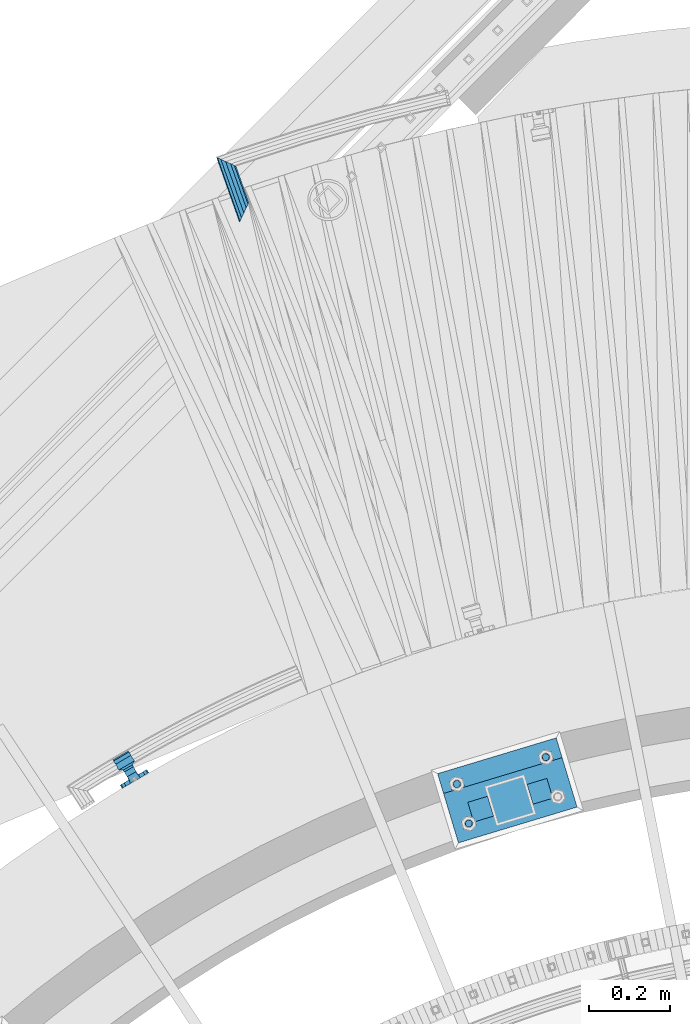
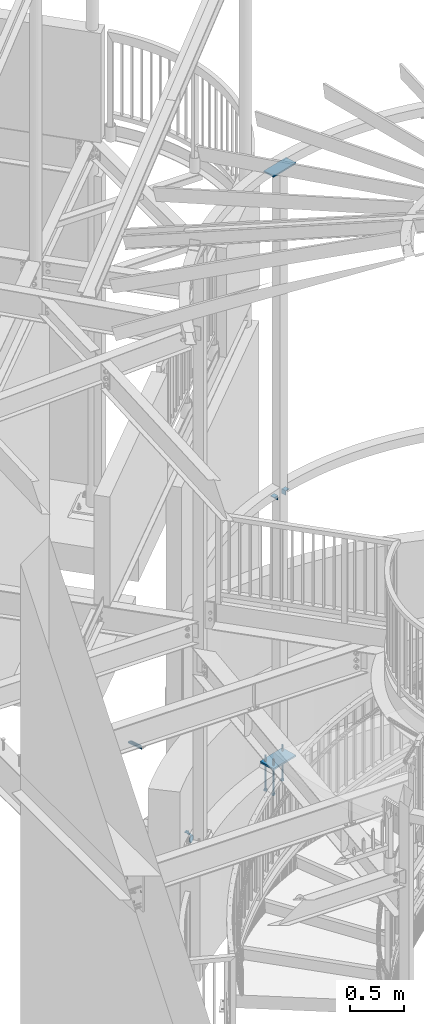
# One storey, part 515 of 975: 9 beams.
"""IFC2X3 building model written with IfcOpenShell, lengths in millimetres."""

from ifc_helpers import new_model, si_unit, frame, origin_with_axes, place, context, subcontext, project, spatial, faceted_brep, material, type_object, element, save


model = new_model("IFC2X3")

# Units and contexts
model_context = context("Model", 3, precision=1e-05, world=origin_with_axes())
body_context = subcontext(model_context, "Body", "Model", "MODEL_VIEW")
ifc_project = project(units=[si_unit("LENGTHUNIT", "METRE", prefix="MILLI"), si_unit("AREAUNIT", "SQUARE_METRE"), si_unit("VOLUMEUNIT", "CUBIC_METRE"), si_unit("MASSUNIT", "GRAM", prefix="KILO"), si_unit("TIMEUNIT", "SECOND"), si_unit("PLANEANGLEUNIT", "RADIAN"), si_unit("SOLIDANGLEUNIT", "STERADIAN"), si_unit("THERMODYNAMICTEMPERATUREUNIT", "DEGREE_CELSIUS"), si_unit("LUMINOUSINTENSITYUNIT", "LUMEN")], contexts=[model_context])

# Site, building, storey
site_placement = place(None, origin_with_axes())
site = spatial("IfcSite", under=ifc_project, at=site_placement, CompositionType="ELEMENT")
building_placement = place(site_placement, origin_with_axes())
building = spatial("IfcBuilding", under=site, at=building_placement, Name="Undefined", CompositionType="ELEMENT")
storey_placement = place(building_placement, origin_with_axes())
storey = spatial("IfcBuildingStorey", under=building, at=storey_placement, Name="Undefined", CompositionType="ELEMENT", Elevation=0.0)

# Beams
ifc_material_1 = material()
beam_type_1 = type_object("IfcBeamType", PredefinedType="NOTDEFINED")
beam_1_placement = place(storey_placement, frame((33075.7481379149, 8151.42269169121, 913.861785244744), z_axis=(-0.0568430869361109, -0.0202261951466153, 0.998178222812672), x_axis=(0.333603898901736, -0.942713332722321, -0.000104618999969072)))
element("IfcBeam", 1, at=beam_1_placement, inside=storey, type_object=beam_type_1, material=ifc_material_1, Name="HANDRAIL", context=body_context, shape_type="Brep", body=[
    faceted_brep([(36.2749286255967, 9.52499999995052, -16.4977839420928), (42.6334301021557, 16.497783941988, -9.52499999999623), (141.473891942826, 16.4977839418207, -9.52499999999054), (148.083092158022, 9.52499999975407, -16.497783942086), (27.1792150478805, 0.0, -19.050000000002), (157.535839107395, -2.18278728425503e-10, -19.0499999999945), (17.7834784767383, -9.5249999999578, -16.4977839420974), (167.299276879601, -9.52500000020518, -16.4977839420885), (10.6052989387044, -16.4977839420317, -9.52500000000373), (174.757300208224, -16.4977839423154, -9.52499999999395), (7.56806384412221, -19.049999999952, -2.27373675443232e-12), (177.911537765233, -19.0500000002357, 7.27595761418343e-12), (9.48559788380817, -16.4977839420753, 9.52499999999986), (175.916814144486, -16.4977839423664, 9.5250000000101), (15.8440993603676, -9.52500000003783, 16.4977839420962), (169.307613929289, -9.52500000029249, 16.4977839421053), (24.939812938087, -9.45874489843845e-11, 19.0500000000056), (159.854866979916, -3.20142135024071e-10, 19.0500000000138), (34.3355495092278, 9.52499999986321, 16.497783942101), (150.091429207714, 9.52499999966676, 16.4977839421076), (41.5137290472626, 16.4977839419444, 9.52500000000737), (142.633405879086, 16.497783941777, 9.52500000001328), (44.5509641418444, 19.0499999998647, 5.91171556152403e-12), (139.479168322079, 19.0499999996973, 1.22781784739345e-11), (32.7355159760868, 7.68349999988277, 13.3082123799622), (25.1562884753671, -8.00355337560177e-11, 15.3670000000047), (17.8190795226737, -7.68350000004284, 13.3082123799581), (12.6898883315812, -13.3082123799541, 7.68350000000032), (11.1430775395675, -15.3669999999693, -1.36424205265939e-12), (13.5931138491992, -13.3082123799104, -7.68350000000305), (19.3835120098793, -7.68349999997008, -13.3082123799584), (26.9627395105986, -7.27595761418343e-12, -15.3670000000011), (34.2999484632924, 7.68349999994825, -13.3082123799545), (39.4291396543854, 13.3082123798595, -7.68349999999668), (40.9759504463982, 15.366999999882, 5.45696821063757e-12), (38.5259141367669, 13.3082123798231, 7.68350000000669), (174.19640871906, -15.3670000002458, 8.18545231595635e-12), (171.651990423074, -13.3082123801869, -7.68349999999327), (165.63585160465, -7.68350000022474, -13.3082123799495), (157.760011801737, -2.3283064365387e-10, -15.3669999999934), (150.134795929244, 7.68349999974453, -13.3082123799472), (144.803374422318, 13.3082123796848, -7.68349999999009), (143.19429736825, 15.3669999997073, 1.13686837721616e-11), (145.738715664237, 13.3082123796412, 7.68350000001283), (151.75485448266, 7.68349999967904, 13.3082123799691), (159.630694285574, -3.05590219795704e-10, 15.3670000000129), (167.255910158066, -7.68350000029022, 13.308212379967), (172.587331664992, -13.3082123802233, 7.68350000000964)], [[[0, 1, 2, 3]], [[4, 0, 3, 5]], [[6, 4, 5, 7]], [[8, 6, 7, 9]], [[10, 8, 9, 11]], [[12, 10, 11, 13]], [[14, 12, 13, 15]], [[16, 14, 15, 17]], [[18, 16, 17, 19]], [[20, 18, 19, 21]], [[22, 20, 21, 23]], [[1, 22, 23, 2]], [[0, 4, 6, 8, 10, 12, 14, 16, 18, 20, 22, 1], [24, 25, 26, 27, 28, 29, 30, 31, 32, 33, 34, 35]], [[29, 28, 36, 37]], [[30, 29, 37, 38]], [[31, 30, 38, 39]], [[32, 31, 39, 40]], [[33, 32, 40, 41]], [[34, 33, 41, 42]], [[35, 34, 42, 43]], [[24, 35, 43, 44]], [[25, 24, 44, 45]], [[26, 25, 45, 46]], [[27, 26, 46, 47]], [[28, 27, 47, 36]], [[7, 5, 3, 2, 23, 21, 19, 17, 15, 13, 11, 9], [46, 45, 44, 43, 42, 41, 40, 39, 38, 37, 36, 47]]]),
])
ifc_material_2 = material(Name="STEEL/A36")
beam_type_2 = type_object("IfcBeamType", PredefinedType="NOTDEFINED")
beam_2_placement = place(storey_placement, frame((32856.3238851668, 6612.17309210685, 812.475739928615), z_axis=(-0.862992370275511, -0.505216917161317, 0.000188308976052212), x_axis=(0.505216929992915, -0.862992382987531, 2.35380000032378e-05)))
element("IfcBeam", 2, at=beam_2_placement, inside=storey, type_object=beam_type_2, material=ifc_material_2, Name="WALL BRACKET", context=body_context, shape_type="Brep", body=[
    faceted_brep([(-1.09139364212751e-11, -35.1998101886752, 14.5802387730655), (0.0, -26.940768363208, 26.9407683632162), (1.2732925824821e-11, -14.5802387731151, 35.1998101887366), (0.0, 0.0, 38.0999984741211), (3.27418092638254e-11, 14.5802387730973, 35.1998101888166), (3.45607986673713e-11, 26.9407683631939, 26.9407683633472), (3.27418092638254e-11, 35.1998101886679, 14.5802387732328), (2.36468622460961e-11, 38.0999999999908, 8.73114913702011e-11), (1.45519152283669e-11, 35.1998101886752, -14.5802387730655), (1.81898940354586e-12, 26.9407683632071, -26.9407683632162), (-1.09139364212751e-11, 14.5802387731146, -35.1998101887511), (0.0, 0.0, -38.0999984741211), (-2.91038304567337e-11, -14.5802387730978, -35.1998101888239), (-3.27418092638254e-11, -26.9407683631948, -26.9407683633617), (-3.09228198602796e-11, -35.1998101886688, -14.5802387732401), (-2.36468622460961e-11, -38.0999999999917, -9.45874489843845e-11), (9.52499999999407, 35.4440469783465, 13.3523775149006), (9.52500000001783, 38.099999999989, 1.23691279441118e-10), (5.45819490078651, 35.1998101886775, 14.58023877304), (5.15915812204861, 35.4440469814256, 13.3523774994246), (5.15916016817869, 35.4440461871586, -13.3523814925829), (5.45819607316758, 35.1998101886757, -14.5802387731565), (9.52499999563867, 35.4440461839649, -13.352381508641), (9.52499999999338, 33.7468954266617, -16.754679378646), (9.52499999999418, 26.9407683632057, -26.9407683631944), (7.23710514487385, 33.7468954167059, -16.7546793935435), (9.52499999997963, 14.5802387731133, -35.199810188722), (9.52499999996871, 7.73070496506989e-12, -38.1000000000931), (9.52499999996326, -14.5802387730996, -35.1998101888021), (9.52499999995962, -26.9407683631966, -26.9407683633399), (9.5249999999578, -35.1998101886768, -14.5802387731064), (9.52499999997235, -38.0999999999935, -7.27595761418343e-11), (9.52499999988504, -35.1998101886779, 14.5802387731401), (9.52499999999418, -26.9407683632098, 26.940768363238), (9.52500000000691, -14.5802387731169, 35.1998101887584), (9.52500000001783, -1.13686837721616e-11, 38.1000000001295), (9.5250000000251, 14.580238773096, 35.1998101888312), (9.52500000002692, 26.9407683631925, 26.9407683633617), (7.23710629084189, 33.7468933804012, 16.7546824409801), (9.52500001802099, 33.74689339, 16.7546824266137), (4.12737783423069, 36.2867482851609, 11.6630037101459), (9.52500001480979, 36.2867482910076, 11.6630037099276), (1.9072828969438, 38.0999998001848, -4.3824766180478e-06), (9.43529109937867, 38.0999998083389, -4.38277129433118e-06), (4.12738199474541, 36.2867456530334, -11.6630120660157), (9.52499999713365, 36.2867456588801, -11.6630120662267), (9.52499998931302, 31.8782691818908, -20.5007361535354), (1.90728516843444, 38.0999984362613, -14.9620414784949), (9.43529504267332, 38.0999984471014, -14.9620414798228), (9.52499998867484, 31.8782692100656, -21.3428983101403), (-0.974480980704527, 40.4536660864392, -13.6176374922397), (6.55352889353486, 40.4536660972792, -13.617637493564), (-3.23293929398841, 48.4467136552532, -12.2071016444133), (-3.86099316375032, 48.9596734302611, -12.3332393299024), (-3.86099415506237, 48.9596734359397, 12.1506042690053), (-3.23294234398753, 48.4467162038179, 12.0244673261113), (6.55352388489973, 40.4536689343606, 13.4350048968336), (9.4352891744017, 38.1000015670843, 14.7794093900302), (-8.88876894391092, 51.462646060533, -12.9487245784876), (-14.5044020842531, 51.5524567377918, -12.9708091785214), (-14.5044031272276, 51.5524567437842, 12.788173508583), (-8.88876998507754, 51.4626460665079, 12.7660889411018), (-16.4483770195459, 51.1442726592504, -12.8704360163174), (-16.4483780543928, 51.1442726651987, 12.6878004343525), (-22.5793182144077, 51.3711360271759, -12.9262221073186), (-22.5793192537777, 51.3711360331463, 12.7435864607032), (-27.8885284154861, 54.4455780358899, -13.6822326528272), (-27.8885295160832, 54.4455780422152, 13.4995963000001), (-28.6196515649072, 55.6169452716154, -13.9702738582564), (-31.1370083013608, 59.6501226213948, -17.5950925222933), (-31.1370097188383, 59.6501226295447, 17.4124524185645), (-28.6196545294583, 55.616948227025, 13.7876379643458), (-33.6296792490059, 67.324805151891, -22.2250062266612), (-32.8101722890036, 64.8016260361878, -22.2250061928717), (-39.3161821982224, 64.9509398614337, -22.2250064563596), (-33.6296810489844, 67.3248051619378, 22.2249937734341), (-39.3127719838823, 64.95236112884, 22.2249935438595), (-32.8101756191698, 64.8016307577993, 22.2249938072164), (-49.8281982508399, 63.7590297560901, -21.2879733583577), (-49.8281999673757, 63.7590297658239, 21.1053316176076), (-62.537662592724, 64.8016282183019, -22.2250073966388), (-62.5376643923654, 64.8016282284259, 22.2249926034456), (-59.3629825026719, 68.3509998487543, 22.2249927311568), (-59.3629807030303, 68.3509998386305, -22.2250072689349), (-56.0005505059879, 61.6533412669896, 22.2249928688907), (-56.0009816237271, 61.6535489521873, 19.2130312653135), (-56.0009816302269, 64.8016307505561, 22.0423689734525), (-51.9930603186979, 64.8016307660225, 22.2249930304133), (-51.9930486616773, 64.8016260085653, -22.2250069696784), (-56.000981616694, 61.6535497473442, -22.2250071312228), (-56.0009816212363, 64.8016260027941, -22.2250068759422), (-56.0009816161877, 61.6535496925769, -19.3956728877092), (-50.6240356350016, 59.0640018412871, -17.0683164176735), (-50.6240370098228, 59.0640018490833, 16.8856764812081), (-37.4851004069614, 60.555058921409, -18.4084041452843), (-37.4851018904596, 60.555058929803, 18.2257636742615), (-36.5628425975134, 60.9400579463424, -18.7544220673662), (-36.5628441090176, 60.9400579547794, 18.5717814508498), (-35.6661101826384, 58.1791091500552, -16.2730189810172), (-35.6661114930633, 58.1791091575863, 16.0903794298065), (-34.0669073739811, 55.616948225869, 13.7876379531408), (-34.0669044052501, 55.6169452637716, -13.9702738572996), (-31.199578137138, 51.0230652214489, -12.8406309028251), (-31.1995791695818, 51.0230652273826, 12.6579953160217), (-13.5258453474495, 46.8920843628518, -12.4814476045976), (-10.0158535806146, 46.8359491542703, -12.491353805628), (-10.0158545847443, 46.8359491600327, 12.308720278641), (-13.5258463507973, 46.8920843686235, 12.298814059428), (-15.4698202757649, 46.4839002842855, -12.5534799881534), (-15.469821284944, 46.4839002900824, 12.3708465294185), (-23.8996230795056, 46.7958284847284, -12.4984339079674), (-23.8996240842331, 46.7958284904998, 12.3158003666576), (-26.7505131823156, 48.4467136213889, -12.207101640266), (-26.7505186046602, 48.4467161988273, 12.0244672777189), (-6.87329577845111, 45.2714927334573, -12.7674339683217), (-6.87329680492121, 45.2714927393397, 12.584800790275), (-0.974485553301008, 40.4536689327629, 13.4350048813394), (1.90728014135857, 38.100001565487, 14.7794093745397), (9.52500002100476, 31.8782677827221, 21.320715892205), (9.52500002038346, 31.878267810155, 20.5007393728483)], [[[0, 1, 2, 3, 4, 5, 6, 7, 8, 9, 10, 11, 12, 13, 14, 15]], [[16, 17, 7, 6, 18, 19]], [[20, 21, 8, 7, 17, 22]], [[23, 24, 9, 8, 21, 25]], [[10, 9, 24, 26]], [[11, 10, 26, 27]], [[12, 11, 27, 28]], [[13, 12, 28, 29]], [[14, 13, 29, 30]], [[15, 14, 30, 31]], [[0, 15, 31, 32]], [[1, 0, 32, 33]], [[2, 1, 33, 34]], [[3, 2, 34, 35]], [[4, 3, 35, 36]], [[5, 4, 36, 37]], [[38, 18, 6, 5, 37, 39]], [[39, 37, 36, 35, 34, 33, 32, 31, 30, 29, 28, 27, 26, 24, 23, 22, 17, 16]], [[40, 41, 16, 19]], [[40, 42, 43, 41]], [[42, 44, 45, 43]], [[46, 23, 25]], [[47, 48, 49]], [[48, 47, 50, 51]], [[51, 52, 53, 54, 55, 56, 57, 48]], [[58, 59, 60, 61]], [[59, 62, 63, 60]], [[62, 64, 65, 63]], [[64, 66, 67, 65]], [[66, 68, 69, 70, 71, 67]], [[72, 73, 74]], [[75, 76, 77]], [[74, 76, 75, 72]], [[74, 78, 79, 76]], [[80, 81, 82, 83]], [[84, 85, 86]], [[82, 81, 84, 86, 87]], [[78, 88, 83, 82, 87, 79]], [[89, 80, 83, 88, 90]], [[89, 90, 91]], [[84, 81, 80, 89, 91, 92, 93, 85]], [[92, 94, 95, 93]], [[94, 96, 97, 95]], [[96, 98, 99, 97]], [[70, 77, 76, 79, 87, 86, 85, 93, 95, 97, 99, 100, 71]], [[69, 73, 72, 75, 77, 70]], [[68, 101, 98, 96, 94, 92, 91, 90, 88, 78, 74, 73, 69]], [[99, 98, 101, 102, 103, 100]], [[104, 105, 106, 107]], [[108, 104, 107, 109]], [[110, 108, 109, 111]], [[103, 102, 112, 110, 111, 113]], [[54, 61, 60, 63, 65, 67, 71, 100, 103, 113, 55]], [[53, 58, 61, 54]], [[52, 112, 102, 101, 68, 66, 64, 62, 59, 58, 53]], [[51, 50, 114, 105, 104, 108, 110, 112, 52]], [[105, 114, 115, 106]], [[55, 113, 111, 109, 107, 106, 115, 116, 56]], [[56, 116, 117, 57]], [[117, 118, 57]], [[39, 16, 41, 43, 45, 22, 23, 46, 49, 48, 57, 118, 119]], [[119, 38, 39]], [[119, 118, 117, 116, 115, 114, 50, 47, 49, 46, 25, 21, 20, 44, 42, 40, 19, 18, 38]], [[45, 44, 20, 22]]]),
])
beam_type_3 = type_object("IfcBeamType", Name="L2X2X1/4", PredefinedType="NOTDEFINED")
for number, where, z_axis, x_axis, name in (
    (3, (33703.1314159098, 6558.02226076022, 4445.0), (-0.957369928409554, -0.288864709123642, 0.0), (0.288864709123643, -0.957369928409553, 0.0), "ANGLE"),
    (4, (33863.7089202229, 6553.41085006745, 4445.0), (0.957369928409554, 0.288864709123642, 0.0), (-0.288864709123643, 0.957369928409553, 0.0), "ANGLE"),
):
    element("IfcBeam", number, at=place(storey_placement, frame(where, z_axis=z_axis, x_axis=x_axis)), inside=storey, type_object=beam_type_3, material=ifc_material_2, Name=name, ObjectType="L2X2X1/4", context=body_context, shape_type="Brep", body=[
        faceted_brep([(0.0, 25.3999999999724, -25.4000000000342), (0.0, 25.400000000016, 25.4000000000196), (50.8000000000102, 25.3999999999996, 25.4000000000015), (50.7999999999411, 25.3999999999996, -25.4000000000487), (3.27418092638254e-11, 19.0500000000002, 25.4000000000269), (50.8000000000102, 19.0500000000002, 25.4000000000015), (-2.5465851649642e-11, 19.0500000000002, -19.0500000000211), (50.7999999999483, 19.0500000000002, -19.0500000000429), (-2.5465851649642e-11, -25.3999999999996, -19.0500000000211), (50.7999999999483, -25.3999999999996, -19.0500000000429), (0.0, -25.400000000016, -25.4000000000196), (50.7999999999411, -25.3999999999996, -25.4000000000487)], [[[0, 1, 2, 3]], [[1, 4, 5, 2]], [[4, 6, 7, 5]], [[6, 8, 9, 7]], [[8, 10, 11, 9]], [[10, 0, 3, 11]], [[5, 7, 9, 11, 3, 2]], [[10, 8, 6, 4, 1, 0]]]),
    ])
beam_type_4 = type_object("IfcBeamType", PredefinedType="NOTDEFINED")
beam_3_placement = place(storey_placement, frame((33637.5169909779, 6511.69357374351, 8170.8625), z_axis=(0.288864709123643, -0.957369928409553, 0.0), x_axis=(0.957369928409554, 0.288864709123642, 0.0)))
element("IfcBeam", 5, at=beam_3_placement, inside=storey, type_object=beam_type_4, material=ifc_material_2, Name="PLATE", context=body_context, shape_type="Brep", body=[
    faceted_brep([(0.0, 7.9375, -63.5), (0.0, 7.9375, 63.5), (304.799999999529, 7.9375, 63.5), (304.799999999529, 7.9375, -63.5), (0.0, -7.9375, 63.5), (304.799999999529, -7.9375, 63.5), (0.0, -7.9375, -63.5), (304.799999999529, -7.9375, -63.5)], [[[0, 1, 2, 3]], [[1, 4, 5, 2]], [[4, 6, 7, 5]], [[6, 0, 3, 7]], [[5, 7, 3, 2]], [[6, 4, 1, 0]]]),
])
ifc_material_3 = material(Name="STEEL/F1554-36")
beam_type_5 = type_object("IfcBeamType", PredefinedType="NOTDEFINED")
beam_4_placement = place(storey_placement, frame((33870.8360600783, 6661.6853801861, 1371.6), z_axis=(-0.957369928409554, -0.288864709123642, 0.0), x_axis=(0.0, 0.0, -1.0)))
element("IfcBeam", 6, at=beam_4_placement, inside=storey, type_object=beam_type_5, material=ifc_material_3, Name="HEADED_ANCHOR_BOLT", context=body_context, shape_type="Brep", body=[
    faceted_brep([(260.34375, -9.13000011445183, 15.8100004195221), (260.34375, -18.2600002289691, -1.45519152283669e-11), (279.393749999999, -18.2600002289691, -1.45519152283669e-11), (279.393749999999, -9.13000011445183, 15.8100004195221), (260.34375, 9.13000011451732, 15.8100004195403), (279.393749999999, 9.13000011451732, 15.8100004195403), (260.34375, 18.2600002289728, 1.81898940354586e-11), (279.393749999999, 18.2600002289728, 1.81898940354586e-11), (260.34375, 9.13000011445547, -15.8100004195221), (279.393749999999, 9.13000011445547, -15.8100004195221), (260.34375, -9.13000011451732, -15.8100004195367), (279.393749999999, -9.13000011451732, -15.8100004195367), (260.34375, -4.47768005528269, 9.29799844174704), (260.34375, -8.06850066050174, 6.43441456486471), (260.34375, -10.0612557562381, 2.29641597050068), (260.34375, -10.0612557562454, -2.29641597051523), (260.34375, -8.06850066052721, -6.43441456487926), (260.34375, -4.47768005531907, -9.29799844175068), (260.34375, -1.81898940354586e-11, -10.319999694766), (260.34375, 4.47768005528633, -9.2979984417434), (260.34375, 8.06850066050174, -6.43441456486471), (260.34375, 10.0612557562381, -2.29641597050068), (260.34375, 10.0612557562454, 2.29641597051886), (260.34375, 8.06850066052357, 6.4344145648829), (260.34375, 4.47768005532271, 9.29799844175432), (260.34375, 2.18278728425503e-11, 10.3199996947696), (279.393749999999, 2.18278728425503e-11, 10.3199996947696), (279.393749999999, -4.47768005528269, 9.29799844174704), (279.393749999999, -8.06850066050174, 6.43441456486471), (279.393749999999, -10.0612557562381, 2.29641597050068), (279.393749999999, -10.0612557562454, -2.29641597051523), (279.393749999999, -8.06850066052721, -6.43441456487926), (279.393749999999, -4.47768005531907, -9.29799844175068), (279.393749999999, -1.81898940354586e-11, -10.319999694766), (279.393749999999, 4.47768005528633, -9.2979984417434), (279.393749999999, 8.06850066050174, -6.43441456486471), (279.393749999999, 10.0612557562381, -2.29641597050068), (279.393749999999, 10.0612557562454, 2.29641597051886), (279.393749999999, 8.06850066052357, 6.4344145648829), (279.393749999999, 4.47768005532271, 9.29799844175432), (0.0, -6.73519209080223, 6.73519209080186), (0.0, -9.52499999999964, 0.0), (279.400000000001, -9.52499999999782, -3.63797880709171e-12), (279.400000000001, -6.73519209079313, 6.73519209079313), (-9.87109982941227e-13, -1.20792265079217e-13, 9.52499961853027), (279.400000000001, 1.09139364212751e-11, 9.52499999999054), (0.0, 6.73519209080223, 6.73519209080186), (279.400000000001, 6.73519209081132, 6.73519209079677), (0.0, 9.52499999999964, 0.0), (279.400000000001, 9.52500000000146, 3.63797880709171e-12), (0.0, 6.73519209080223, -6.73519209080186), (279.400000000001, 6.73519209079677, -6.73519209079313), (2.95075507493764e-12, -1.20792265079217e-13, -9.52499961853027), (279.400000000001, -1.09139364212751e-11, -9.5249999999869), (-126.99791499542, -6.36396103070001, 6.3639610306418), (-126.99791499542, 1.81898940354586e-11, 8.99999999995271), (-126.99791499542, 6.36396103072184, 6.36396103065272), (-126.99791499542, 9.00000000004366, 1.09139364212751e-11), (-126.99791499542, 6.36396103069637, -6.3639610306418), (-126.99791499542, -1.81898940354586e-11, -8.99999999995271), (-126.99791499542, -6.36396103072184, -6.36396103064908), (-126.99791499542, -9.00000000004002, -7.27595761418343e-12), (0.0149743263646087, 6.36396103067818, -6.36396103067909), (0.0149743263646087, 0.0, -9.0), (0.0149743263646087, -6.36396103067818, -6.36396103067909), (0.0149743263987148, -8.9999995411581, -1.00796984270346e-06), (0.0149743263646087, -6.36396103067818, 6.36396103067909), (0.0149743263646087, 0.0, 9.0), (0.0149743263646087, 6.36396103067818, 6.36396103067909), (0.0149743263987148, 9.0000004588419, -1.00796984270346e-06), (0.0, -6.73519209080223, -6.73519209080186), (279.400000000001, -6.73519209080769, -6.73519209079677)], [[[0, 1, 2, 3]], [[4, 0, 3, 5]], [[6, 4, 5, 7]], [[8, 6, 7, 9]], [[10, 8, 9, 11]], [[0, 4, 6, 8, 10, 1], [12, 13, 14, 15, 16, 17, 18, 19, 20, 21, 22, 23, 24, 25]], [[12, 25, 26, 27]], [[13, 12, 27, 28]], [[14, 13, 28, 29]], [[15, 14, 29, 30]], [[16, 15, 30, 31]], [[17, 16, 31, 32]], [[18, 17, 32, 33]], [[19, 18, 33, 34]], [[20, 19, 34, 35]], [[21, 20, 35, 36]], [[22, 21, 36, 37]], [[23, 22, 37, 38]], [[24, 23, 38, 39]], [[25, 24, 39, 26]], [[9, 7, 5, 3, 2, 11], [38, 37, 36, 35, 34, 33, 32, 31, 30, 29, 28, 27, 26, 39]], [[1, 10, 11, 2]], [[40, 41, 42, 43]], [[44, 40, 43, 45]], [[46, 44, 45, 47]], [[48, 46, 47, 49]], [[50, 48, 49, 51]], [[52, 50, 51, 53]], [[54, 55, 56, 57, 58, 59, 60, 61]], [[59, 58, 62, 63]], [[60, 59, 63, 64]], [[61, 60, 64, 65]], [[54, 61, 65, 66]], [[55, 54, 66, 67]], [[56, 55, 67, 68]], [[57, 56, 68, 69]], [[58, 57, 69, 62]], [[40, 44, 46, 48, 50, 52, 70, 41], [68, 67, 66, 65, 64, 63, 62, 69]], [[41, 70, 71, 42]], [[53, 51, 49, 47, 45, 43, 42, 71]], [[70, 52, 53, 71]]]),
])
beam_5_placement = place(storey_placement, frame((33681.3299546868, 6498.38212477162, 1371.6), z_axis=(0.957369928409554, 0.288864709123642, 0.0), x_axis=(0.0, 0.0, -1.0)))
element("IfcBeam", 7, at=beam_5_placement, inside=storey, type_object=beam_type_5, material=ifc_material_3, Name="HEADED_ANCHOR_BOLT", context=body_context, shape_type="Brep", body=[
    faceted_brep([(260.34375, -9.13000011445183, 15.8100004195221), (260.34375, -18.2600002289691, -1.45519152283669e-11), (279.393749999999, -18.2600002289691, -1.45519152283669e-11), (279.393749999999, -9.13000011445183, 15.8100004195221), (260.34375, 9.13000011451732, 15.8100004195403), (279.393749999999, 9.13000011451732, 15.8100004195403), (260.34375, 18.2600002289728, 1.81898940354586e-11), (279.393749999999, 18.2600002289728, 1.81898940354586e-11), (260.34375, 9.13000011445547, -15.8100004195221), (279.393749999999, 9.13000011445547, -15.8100004195221), (260.34375, -9.13000011451732, -15.8100004195367), (279.393749999999, -9.13000011451732, -15.8100004195367), (260.34375, -4.47768005528269, 9.29799844174704), (260.34375, -8.06850066050174, 6.43441456486471), (260.34375, -10.0612557562381, 2.29641597050068), (260.34375, -10.0612557562454, -2.29641597051523), (260.34375, -8.06850066052721, -6.43441456487926), (260.34375, -4.47768005531907, -9.29799844175068), (260.34375, -1.81898940354586e-11, -10.319999694766), (260.34375, 4.47768005528633, -9.2979984417434), (260.34375, 8.06850066050174, -6.43441456486471), (260.34375, 10.0612557562381, -2.29641597050068), (260.34375, 10.0612557562454, 2.29641597051886), (260.34375, 8.06850066052357, 6.4344145648829), (260.34375, 4.47768005532271, 9.29799844175432), (260.34375, 2.18278728425503e-11, 10.3199996947696), (279.393749999999, 2.18278728425503e-11, 10.3199996947696), (279.393749999999, -4.47768005528269, 9.29799844174704), (279.393749999999, -8.06850066050174, 6.43441456486471), (279.393749999999, -10.0612557562381, 2.29641597050068), (279.393749999999, -10.0612557562454, -2.29641597051523), (279.393749999999, -8.06850066052721, -6.43441456487926), (279.393749999999, -4.47768005531907, -9.29799844175068), (279.393749999999, -1.81898940354586e-11, -10.319999694766), (279.393749999999, 4.47768005528633, -9.2979984417434), (279.393749999999, 8.06850066050174, -6.43441456486471), (279.393749999999, 10.0612557562381, -2.29641597050068), (279.393749999999, 10.0612557562454, 2.29641597051886), (279.393749999999, 8.06850066052357, 6.4344145648829), (279.393749999999, 4.47768005532271, 9.29799844175432), (0.0, -6.73519209080223, 6.73519209080186), (0.0, -9.52499999999964, 0.0), (279.400000000001, -9.52499999999782, -3.63797880709171e-12), (279.400000000001, -6.73519209079313, 6.73519209079313), (-9.87109982941227e-13, -1.20792265079217e-13, 9.52499961853027), (279.400000000001, 1.09139364212751e-11, 9.52499999999054), (0.0, 6.73519209080223, 6.73519209080186), (279.400000000001, 6.73519209081132, 6.73519209079677), (0.0, 9.52499999999964, 0.0), (279.400000000001, 9.52500000000146, 3.63797880709171e-12), (0.0, 6.73519209080223, -6.73519209080186), (279.400000000001, 6.73519209079677, -6.73519209079313), (2.95075507493764e-12, -1.20792265079217e-13, -9.52499961853027), (279.400000000001, -1.09139364212751e-11, -9.5249999999869), (-126.99791499542, -6.36396103070001, 6.3639610306418), (-126.99791499542, 1.81898940354586e-11, 8.99999999995271), (-126.99791499542, 6.36396103072184, 6.36396103065272), (-126.99791499542, 9.00000000004366, 1.09139364212751e-11), (-126.99791499542, 6.36396103069637, -6.3639610306418), (-126.99791499542, -1.81898940354586e-11, -8.99999999995271), (-126.99791499542, -6.36396103072184, -6.36396103064908), (-126.99791499542, -9.00000000004002, -7.27595761418343e-12), (0.0149743263646087, 6.36396103067818, -6.36396103067909), (0.0149743263646087, 0.0, -9.0), (0.0149743263646087, -6.36396103067818, -6.36396103067909), (0.0149743263987148, -8.9999995411581, -1.00796984270346e-06), (0.0149743263646087, -6.36396103067818, 6.36396103067909), (0.0149743263646087, 0.0, 9.0), (0.0149743263646087, 6.36396103067818, 6.36396103067909), (0.0149743263987148, 9.0000004588419, -1.00796984270346e-06), (0.0, -6.73519209080223, -6.73519209080186), (279.400000000001, -6.73519209080769, -6.73519209079677)], [[[0, 1, 2, 3]], [[4, 0, 3, 5]], [[6, 4, 5, 7]], [[8, 6, 7, 9]], [[10, 8, 9, 11]], [[0, 4, 6, 8, 10, 1], [12, 13, 14, 15, 16, 17, 18, 19, 20, 21, 22, 23, 24, 25]], [[12, 25, 26, 27]], [[13, 12, 27, 28]], [[14, 13, 28, 29]], [[15, 14, 29, 30]], [[16, 15, 30, 31]], [[17, 16, 31, 32]], [[18, 17, 32, 33]], [[19, 18, 33, 34]], [[20, 19, 34, 35]], [[21, 20, 35, 36]], [[22, 21, 36, 37]], [[23, 22, 37, 38]], [[24, 23, 38, 39]], [[25, 24, 39, 26]], [[9, 7, 5, 3, 2, 11], [38, 37, 36, 35, 34, 33, 32, 31, 30, 29, 28, 27, 26, 39]], [[1, 10, 11, 2]], [[40, 41, 42, 43]], [[44, 40, 43, 45]], [[46, 44, 45, 47]], [[48, 46, 47, 49]], [[50, 48, 49, 51]], [[52, 50, 51, 53]], [[54, 55, 56, 57, 58, 59, 60, 61]], [[59, 58, 62, 63]], [[60, 59, 63, 64]], [[61, 60, 64, 65]], [[54, 61, 65, 66]], [[55, 54, 66, 67]], [[56, 55, 67, 68]], [[57, 56, 68, 69]], [[58, 57, 69, 62]], [[40, 44, 46, 48, 50, 52, 70, 41], [68, 67, 66, 65, 64, 63, 62, 69]], [[41, 70, 71, 42]], [[53, 51, 49, 47, 45, 43, 42, 71]], [[70, 52, 53, 71]]]),
])
beam_6_placement = place(storey_placement, frame((33651.9812944246, 6595.65090774363, 1371.6), z_axis=(-0.957369928409554, -0.288864709123642, 0.0), x_axis=(0.0, 0.0, -1.0)))
element("IfcBeam", 8, at=beam_6_placement, inside=storey, type_object=beam_type_5, material=ifc_material_3, Name="HEADED_ANCHOR_BOLT", context=body_context, shape_type="Brep", body=[
    faceted_brep([(260.34375, -9.13000011445183, 15.8100004195221), (260.34375, -18.2600002289691, -1.45519152283669e-11), (279.393749999999, -18.2600002289691, -1.45519152283669e-11), (279.393749999999, -9.13000011445183, 15.8100004195221), (260.34375, 9.13000011451732, 15.8100004195403), (279.393749999999, 9.13000011451732, 15.8100004195403), (260.34375, 18.2600002289728, 1.81898940354586e-11), (279.393749999999, 18.2600002289728, 1.81898940354586e-11), (260.34375, 9.13000011445547, -15.8100004195221), (279.393749999999, 9.13000011445547, -15.8100004195221), (260.34375, -9.13000011451732, -15.8100004195367), (279.393749999999, -9.13000011451732, -15.8100004195367), (260.34375, -4.47768005528269, 9.29799844174704), (260.34375, -8.06850066050174, 6.43441456486471), (260.34375, -10.0612557562381, 2.29641597050068), (260.34375, -10.0612557562454, -2.29641597051523), (260.34375, -8.06850066052721, -6.43441456487926), (260.34375, -4.47768005531907, -9.29799844175068), (260.34375, -1.81898940354586e-11, -10.319999694766), (260.34375, 4.47768005528633, -9.2979984417434), (260.34375, 8.06850066050174, -6.43441456486471), (260.34375, 10.0612557562381, -2.29641597050068), (260.34375, 10.0612557562454, 2.29641597051886), (260.34375, 8.06850066052357, 6.4344145648829), (260.34375, 4.47768005532271, 9.29799844175432), (260.34375, 2.18278728425503e-11, 10.3199996947696), (279.393749999999, 2.18278728425503e-11, 10.3199996947696), (279.393749999999, -4.47768005528269, 9.29799844174704), (279.393749999999, -8.06850066050174, 6.43441456486471), (279.393749999999, -10.0612557562381, 2.29641597050068), (279.393749999999, -10.0612557562454, -2.29641597051523), (279.393749999999, -8.06850066052721, -6.43441456487926), (279.393749999999, -4.47768005531907, -9.29799844175068), (279.393749999999, -1.81898940354586e-11, -10.319999694766), (279.393749999999, 4.47768005528633, -9.2979984417434), (279.393749999999, 8.06850066050174, -6.43441456486471), (279.393749999999, 10.0612557562381, -2.29641597050068), (279.393749999999, 10.0612557562454, 2.29641597051886), (279.393749999999, 8.06850066052357, 6.4344145648829), (279.393749999999, 4.47768005532271, 9.29799844175432), (0.0, -6.73519209080223, 6.73519209080186), (0.0, -9.52499999999964, 0.0), (279.400000000001, -9.52499999999782, -3.63797880709171e-12), (279.400000000001, -6.73519209079313, 6.73519209079313), (-9.87109982941227e-13, -1.20792265079217e-13, 9.52499961853027), (279.400000000001, 1.09139364212751e-11, 9.52499999999054), (0.0, 6.73519209080223, 6.73519209080186), (279.400000000001, 6.73519209081132, 6.73519209079677), (0.0, 9.52499999999964, 0.0), (279.400000000001, 9.52500000000146, 3.63797880709171e-12), (0.0, 6.73519209080223, -6.73519209080186), (279.400000000001, 6.73519209079677, -6.73519209079313), (2.95075507493764e-12, -1.20792265079217e-13, -9.52499961853027), (279.400000000001, -1.09139364212751e-11, -9.5249999999869), (-126.99791499542, -6.36396103070001, 6.3639610306418), (-126.99791499542, 1.81898940354586e-11, 8.99999999995271), (-126.99791499542, 6.36396103072184, 6.36396103065272), (-126.99791499542, 9.00000000004366, 1.09139364212751e-11), (-126.99791499542, 6.36396103069637, -6.3639610306418), (-126.99791499542, -1.81898940354586e-11, -8.99999999995271), (-126.99791499542, -6.36396103072184, -6.36396103064908), (-126.99791499542, -9.00000000004002, -7.27595761418343e-12), (0.0149743263646087, 6.36396103067818, -6.36396103067909), (0.0149743263646087, 0.0, -9.0), (0.0149743263646087, -6.36396103067818, -6.36396103067909), (0.0149743263987148, -8.9999995411581, -1.00796984270346e-06), (0.0149743263646087, -6.36396103067818, 6.36396103067909), (0.0149743263646087, 0.0, 9.0), (0.0149743263646087, 6.36396103067818, 6.36396103067909), (0.0149743263987148, 9.0000004588419, -1.00796984270346e-06), (0.0, -6.73519209080223, -6.73519209080186), (279.400000000001, -6.73519209080769, -6.73519209079677)], [[[0, 1, 2, 3]], [[4, 0, 3, 5]], [[6, 4, 5, 7]], [[8, 6, 7, 9]], [[10, 8, 9, 11]], [[0, 4, 6, 8, 10, 1], [12, 13, 14, 15, 16, 17, 18, 19, 20, 21, 22, 23, 24, 25]], [[12, 25, 26, 27]], [[13, 12, 27, 28]], [[14, 13, 28, 29]], [[15, 14, 29, 30]], [[16, 15, 30, 31]], [[17, 16, 31, 32]], [[18, 17, 32, 33]], [[19, 18, 33, 34]], [[20, 19, 34, 35]], [[21, 20, 35, 36]], [[22, 21, 36, 37]], [[23, 22, 37, 38]], [[24, 23, 38, 39]], [[25, 24, 39, 26]], [[9, 7, 5, 3, 2, 11], [38, 37, 36, 35, 34, 33, 32, 31, 30, 29, 28, 27, 26, 39]], [[1, 10, 11, 2]], [[40, 41, 42, 43]], [[44, 40, 43, 45]], [[46, 44, 45, 47]], [[48, 46, 47, 49]], [[50, 48, 49, 51]], [[52, 50, 51, 53]], [[54, 55, 56, 57, 58, 59, 60, 61]], [[59, 58, 62, 63]], [[60, 59, 63, 64]], [[61, 60, 64, 65]], [[54, 61, 65, 66]], [[55, 54, 66, 67]], [[56, 55, 67, 68]], [[57, 56, 68, 69]], [[58, 57, 69, 62]], [[40, 44, 46, 48, 50, 52, 70, 41], [68, 67, 66, 65, 64, 63, 62, 69]], [[41, 70, 71, 42]], [[53, 51, 49, 47, 45, 43, 42, 71]], [[70, 52, 53, 71]]]),
])
beam_type_6 = type_object("IfcBeamType", PredefinedType="NOTDEFINED")
beam_7_placement = place(storey_placement, frame((33630.179827359, 6536.01076996915, 1419.225), z_axis=(-0.288864709123643, 0.957369928409553, 0.0), x_axis=(0.957369928409554, 0.288864709123642, 0.0)))
element("IfcBeam", 9, at=beam_7_placement, inside=storey, type_object=beam_type_6, material=ifc_material_2, Name="PLATE", context=body_context, shape_type="Brep", body=[
    faceted_brep([(0.0, 9.52499999999964, -88.9000000000015), (0.0, 9.52499999999964, 88.9000000000015), (304.800000000429, 9.52500000000009, 88.9000000003653), (304.800000000414, 9.52500000000009, -88.8999999996704), (0.0, -9.52499999999964, 88.9000000000015), (304.800000000429, -9.52500000000009, 88.9000000003653), (0.0, -9.52499999999964, -88.9000000000015), (304.800000000414, -9.52500000000009, -88.8999999996704)], [[[0, 1, 2, 3]], [[1, 4, 5, 2]], [[4, 6, 7, 5]], [[6, 0, 3, 7]], [[5, 7, 3, 2]], [[6, 4, 1, 0]]]),
])

save(model, "model.ifc")
